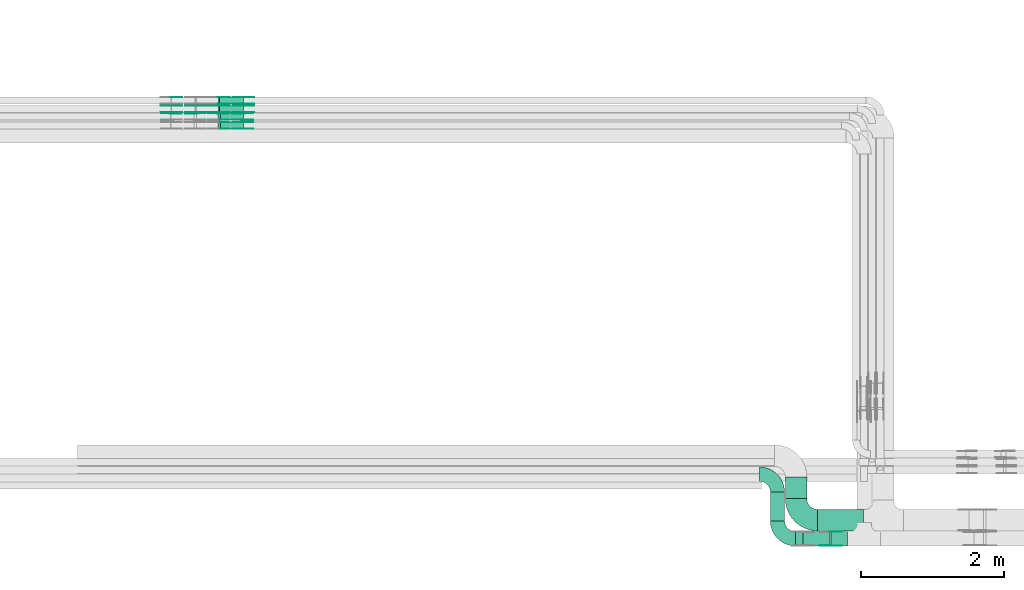
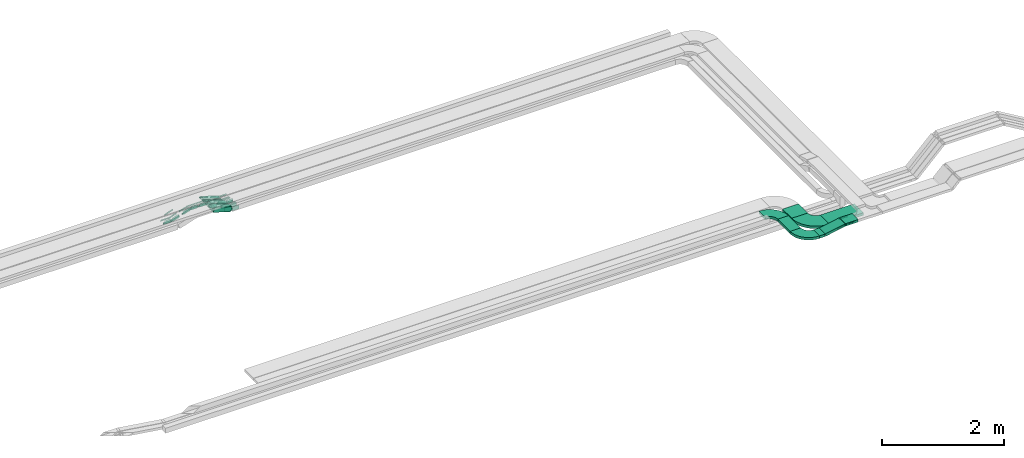
# One storey, part 13 of 19: 46 flow fittings, 10 flow segments.
"""IFC2X3 building model written with IfcOpenShell, lengths in millimetres."""

from ifc_helpers import new_model, entity, si_unit, converted_unit, derived_unit, direction, frame, frame_2d, origin, origin_2d_with_axis, place, context, subcontext, project, spatial, polyline, circle_curve, parameter, trimmed, segment, composite_curve, rectangle, outline, extrude, source, transform, mapped, material, type_object, type_shapes, element, save


model = new_model("IFC2X3")

# Units and contexts
model_context = context("Model", 3, precision=0.01, world=origin(), true_north=direction((6.12303176911189e-17, 1.0)))
body_context = subcontext(model_context, "Body", "Model", "MODEL_VIEW")
ifc_project = project(units=[si_unit("LENGTHUNIT", "METRE", prefix="MILLI"), si_unit("AREAUNIT", "SQUARE_METRE"), si_unit("VOLUMEUNIT", "CUBIC_METRE"), converted_unit("PLANEANGLEUNIT", "DEGREE", entity("IfcRatioMeasure", 0.0174532925199433), si_unit("PLANEANGLEUNIT", "RADIAN"), dimensions=[0, 0, 0, 0, 0, 0, 0]), si_unit("MASSUNIT", "GRAM", prefix="KILO"), derived_unit("MASSDENSITYUNIT", [(si_unit("MASSUNIT", "GRAM", prefix="KILO"), 1), (si_unit("LENGTHUNIT", "METRE"), -3)]), derived_unit("MOMENTOFINERTIAUNIT", [(si_unit("LENGTHUNIT", "METRE"), 4)]), si_unit("TIMEUNIT", "SECOND"), si_unit("FREQUENCYUNIT", "HERTZ"), si_unit("THERMODYNAMICTEMPERATUREUNIT", "DEGREE_CELSIUS"), derived_unit("THERMALTRANSMITTANCEUNIT", [(si_unit("MASSUNIT", "GRAM", prefix="KILO"), 1), (si_unit("THERMODYNAMICTEMPERATUREUNIT", "KELVIN"), -1), (si_unit("TIMEUNIT", "SECOND"), -3)]), derived_unit("VOLUMETRICFLOWRATEUNIT", [(si_unit("LENGTHUNIT", "METRE"), 3), (si_unit("TIMEUNIT", "SECOND"), -1)]), derived_unit("MASSFLOWRATEUNIT", [(si_unit("MASSUNIT", "GRAM", prefix="KILO"), 1), (si_unit("TIMEUNIT", "SECOND"), -1)]), derived_unit("ROTATIONALFREQUENCYUNIT", [(si_unit("TIMEUNIT", "SECOND"), -1)]), si_unit("ELECTRICCURRENTUNIT", "AMPERE"), si_unit("ELECTRICVOLTAGEUNIT", "VOLT"), si_unit("POWERUNIT", "WATT"), si_unit("FORCEUNIT", "NEWTON", prefix="KILO"), si_unit("ILLUMINANCEUNIT", "LUX"), si_unit("LUMINOUSFLUXUNIT", "LUMEN"), si_unit("LUMINOUSINTENSITYUNIT", "CANDELA"), derived_unit("USERDEFINED", [(si_unit("MASSUNIT", "GRAM", prefix="KILO"), -1), (si_unit("LENGTHUNIT", "METRE"), -2), (si_unit("TIMEUNIT", "SECOND"), 3), (si_unit("LUMINOUSFLUXUNIT", "LUMEN"), 1)]), derived_unit("LINEARVELOCITYUNIT", [(si_unit("LENGTHUNIT", "METRE"), 1), (si_unit("TIMEUNIT", "SECOND"), -1)]), si_unit("PRESSUREUNIT", "PASCAL"), derived_unit("USERDEFINED", [(si_unit("LENGTHUNIT", "METRE"), -2), (si_unit("MASSUNIT", "GRAM", prefix="KILO"), 1), (si_unit("TIMEUNIT", "SECOND"), -2)]), derived_unit("LINEARFORCEUNIT", [(si_unit("MASSUNIT", "GRAM", prefix="KILO"), 1), (si_unit("LENGTHUNIT", "METRE"), 1), (si_unit("TIMEUNIT", "SECOND"), -2), (si_unit("LENGTHUNIT", "METRE"), -1)]), derived_unit("PLANARFORCEUNIT", [(si_unit("MASSUNIT", "GRAM", prefix="KILO"), 1), (si_unit("LENGTHUNIT", "METRE"), 1), (si_unit("TIMEUNIT", "SECOND"), -2), (si_unit("LENGTHUNIT", "METRE"), -2)])], contexts=[model_context])

# Site, building, storey
site_placement = place(None, origin())
site = spatial("IfcSite", under=ifc_project, at=site_placement, CompositionType="ELEMENT")
building_placement = place(site_placement, origin())
building = spatial("IfcBuilding", under=site, at=building_placement, CompositionType="ELEMENT")
storey_placement = place(building_placement, frame((0.0, 0.0, 12000.0)))
storey = spatial("IfcBuildingStorey", under=building, at=storey_placement, CompositionType="ELEMENT", Elevation=12000.0)

# Flow segments
cable_carrier_segment_type = type_object("IfcCableCarrierSegmentType", PredefinedType="CABLETRAYSEGMENT")
flow_segment_1_placement = place(storey_placement, frame((51166.35, 14792.5, 2502.95)))
element("IfcFlowSegment", 1, at=flow_segment_1_placement, inside=storey, type_object=cable_carrier_segment_type, context=body_context, shape_type="SweptSolid", body=[
    extrude(rectangle(XDim=50.0000000000005, YDim=99.9999999999989, at=origin_2d_with_axis()), frame((7.73, 50.0, 131.57), z_axis=(0.951056516295132, 0.0, -0.309016994375015), x_axis=(0.309016994375015, 0.0, 0.951056516295132)), (0.0, 0.0, 1.0), 348.813702461219),
])
flow_segment_2_placement = place(storey_placement, frame((51166.35, 14673.63, 2502.95)))
element("IfcFlowSegment", 2, at=flow_segment_2_placement, inside=storey, type_object=cable_carrier_segment_type, context=body_context, shape_type="SweptSolid", body=[
    extrude(rectangle(XDim=50.0000000000005, YDim=99.9999999999989, at=origin_2d_with_axis()), frame((7.73, 50.0, 131.57), z_axis=(0.951056516295132, 0.0, -0.309016994375015), x_axis=(0.309016994375015, 0.0, 0.951056516295132)), (0.0, 0.0, 1.0), 348.813702461386),
])
flow_segment_3_placement = place(storey_placement, frame((51159.12, 14442.5, 2505.4)))
element("IfcFlowSegment", 3, at=flow_segment_3_placement, inside=storey, type_object=cable_carrier_segment_type, context=body_context, shape_type="SweptSolid", body=[
    extrude(rectangle(XDim=100.000000000001, YDim=99.9999999999989, at=origin_2d_with_axis()), frame((15.45, 50.0, 152.9), z_axis=(0.951056516295132, 0.0, -0.309016994375015), x_axis=(0.309016994375015, 0.0, 0.951056516295132)), (0.0, 0.0, 1.0), 340.89448044528),
])
flow_segment_4_placement = place(storey_placement, frame((59726.19, 8613.82, 2870.0)))
element("IfcFlowSegment", 4, at=flow_segment_4_placement, inside=storey, type_object=cable_carrier_segment_type, context=body_context, shape_type="SweptSolid", body=[
    extrude(rectangle(XDim=236.362563853772, YDim=200.0, at=origin_2d_with_axis()), frame((118.18, 100.0, 0.0)), (0.0, 0.0, 1.0), 49.9999999999995),
])
flow_segment_5_placement = place(storey_placement, frame((51159.12, 14566.24, 2505.4)))
element("IfcFlowSegment", 5, at=flow_segment_5_placement, inside=storey, type_object=cable_carrier_segment_type, context=body_context, shape_type="SweptSolid", body=[
    extrude(rectangle(XDim=100.000000000001, YDim=99.9999999999989, at=origin_2d_with_axis()), frame((15.45, 50.0, 152.9), z_axis=(0.951056516295132, 0.0, -0.309016994375015), x_axis=(0.309016994375015, 0.0, 0.951056516295132)), (0.0, 0.0, 1.0), 340.894480445334),
])
flow_segment_6_placement = place(storey_placement, frame((59339.96, 8613.82, 2801.07)))
element("IfcFlowSegment", 6, at=flow_segment_6_placement, inside=storey, type_object=cable_carrier_segment_type, context=body_context, shape_type="SweptSolid", body=[
    extrude(rectangle(XDim=50.0000000000028, YDim=200.0, at=frame_2d((0.0, 0.0), x_axis=(0.0, 1.0))), frame((4.51, 100.0, 24.59), z_axis=(0.98359332593574, 0.0, 0.180400025428684), x_axis=(0.0, 1.0, 0.0)), (0.0, 0.0, 1.0), 380.751680548762),
])
flow_segment_7_placement = place(storey_placement, frame((59231.89, 8613.82, 2800.0)))
element("IfcFlowSegment", 7, at=flow_segment_7_placement, inside=storey, type_object=cable_carrier_segment_type, context=body_context, shape_type="SweptSolid", body=[
    extrude(rectangle(XDim=105.36256385375, YDim=200.0, at=origin_2d_with_axis()), frame((52.68, 100.0, 0.0), z_axis=(0.0, 0.0, 1.0), x_axis=(-1.0, 0.0, 0.0)), (0.0, 0.0, 1.0), 50.0000000000016),
])
flow_segment_8_placement = place(storey_placement, frame((58880.89, 8964.82, 2800.0)))
element("IfcFlowSegment", 8, at=flow_segment_8_placement, inside=storey, type_object=cable_carrier_segment_type, context=body_context, shape_type="SweptSolid", body=[
    extrude(rectangle(XDim=401.312790454062, YDim=200.000000000007, at=origin_2d_with_axis()), frame((100.0, 200.66, 0.0), z_axis=(0.0, 0.0, 1.0), x_axis=(0.0, 1.0, 0.0)), (0.0, 0.0, 1.0), 50.0000000000016),
])
flow_segment_9_placement = place(storey_placement, frame((59541.89, 8824.99, 2800.0)))
element("IfcFlowSegment", 9, at=flow_segment_9_placement, inside=storey, type_object=cable_carrier_segment_type, context=body_context, shape_type="SweptSolid", body=[
    extrude(rectangle(XDim=640.660327660523, YDim=299.999999999999, at=origin_2d_with_axis()), frame((320.33, 150.0, 0.0), z_axis=(0.0, 0.0, 1.0), x_axis=(-1.0, 0.0, 0.0)), (0.0, 0.0, 1.0), 50.0000000000016),
])
flow_segment_10_placement = place(storey_placement, frame((59090.89, 9275.99, 2800.0)))
element("IfcFlowSegment", 10, at=flow_segment_10_placement, inside=storey, type_object=cable_carrier_segment_type, context=body_context, shape_type="SweptSolid", body=[
    extrude(rectangle(XDim=300.142155039271, YDim=300.000000000001, at=origin_2d_with_axis()), frame((150.0, 150.07, 0.0), z_axis=(0.0, 0.0, 1.0), x_axis=(0.0, 1.0, 0.0)), (0.0, 0.0, 1.0), 50.0000000000016),
])

# Flow fittings
ifc_material_1 = material()
cable_carrier_fitting_type_1 = type_object("IfcCableCarrierFittingType", Name="470_DKC_S5_Variable Angle Elbow 0-45:-", PredefinedType="NOTDEFINED", material=ifc_material_1)
shared_shape_1 = source(origin(), body_context, "Body", "SweptSolid", [
    extrude(outline(composite_curve([segment(polyline([(-150.75, -300.25), (-149.75, -300.25)]), True, "CONTINUOUS"), segment(trimmed(circle_curve(frame_2d((-149.75, 149.75), x_axis=(0.0, -1.0)), 450.0), [parameter(0.0)], [parameter(90.0000000000001)], True, "PARAMETER"), True, "CONTINUOUS"), segment(polyline([(300.25, 149.75), (300.25, 150.75)]), True, "CONTINUOUS"), segment(polyline([(300.25, 150.75), (0.25, 150.75)]), True, "CONTINUOUS"), segment(polyline([(0.25, 150.75), (0.25, 149.75)]), True, "CONTINUOUS"), segment(trimmed(circle_curve(frame_2d((-149.75, 149.75), x_axis=(0.0, -1.0)), 150.0), [parameter(0.0)], [parameter(90.0000000000001)], True, "PARAMETER"), False, "CONTINUOUS"), segment(polyline([(-149.75, -0.25), (-150.75, -0.25)]), True, "CONTINUOUS"), segment(polyline([(-150.75, -0.25), (-150.75, -300.25)]), True, "CONTINUOUS")], self_intersect=False)), frame((-150.25, 150.25, -25.0)), (0.0, 0.0, 1.0), 49.9999999999974),
])
type_shapes(cable_carrier_fitting_type_1, [shared_shape_1])
flow_fitting_1_placement = place(storey_placement, frame((59240.89, 8974.99, 2825.0), z_axis=(0.0, 0.0, 1.0), x_axis=(0.0, -1.0, 0.0)))
element("IfcFlowFitting", 11, at=flow_fitting_1_placement, inside=storey, type_object=cable_carrier_fitting_type_1, material=ifc_material_1, Name="470_DKC_S5_Variable Angle Elbow 0-45:-", ObjectType="470_DKC_S5_Variable Angle Elbow 0-45:-", context=body_context, shape_type="MappedRepresentation", body=[
    mapped(shared_shape_1, transform((0.0, 0.0, 0.0), scale=1.0)),
])
ifc_material_2 = material(Name="G")
cable_carrier_fitting_type_2 = type_object("IfcCableCarrierFittingType", PredefinedType="NOTDEFINED", material=ifc_material_2)
shared_shape_2 = source(origin(), body_context, "Body", "SweptSolid", [
    extrude(outline(composite_curve([segment(trimmed(circle_curve(frame_2d((-44.59, 0.0), x_axis=(1.0, 0.0)), 12.5), [parameter(90.0000000000007)], [parameter(270.0)], True, "PARAMETER"), True, "CONTINUOUS"), segment(polyline([(-44.59, -12.5), (-33.09, -12.5)]), True, "CONTINUOUS"), segment(polyline([(-33.09, -12.5), (-31.23, -14.5)]), True, "CONTINUOUS"), segment(polyline([(-31.23, -14.5), (108.91, -14.5)]), True, "CONTINUOUS"), segment(polyline([(108.91, -14.5), (108.91, 14.5)]), True, "CONTINUOUS"), segment(polyline([(108.91, 14.5), (-31.23, 14.5)]), True, "CONTINUOUS"), segment(polyline([(-31.23, 14.5), (-33.09, 12.5)]), True, "CONTINUOUS"), segment(polyline([(-33.09, 12.5), (-44.59, 12.5)]), True, "CONTINUOUS")], self_intersect=False)), frame((44.59, 0.0, 0.0), z_axis=(0.0, 0.0, -1.0), x_axis=(1.0, 0.0, 0.0)), (0.0, 0.0, -1.0), 2.0),
])
type_shapes(cable_carrier_fitting_type_2, [shared_shape_2])
flow_fitting_2_placement = place(storey_placement, frame((51511.13, 14887.96, 2525.0), z_axis=(0.0, 1.0, 0.0), x_axis=(-0.951056516295154, 0.0, 0.309016994374945)))
element("IfcFlowFitting", 12, at=flow_fitting_2_placement, inside=storey, type_object=cable_carrier_fitting_type_2, material=ifc_material_2, context=body_context, shape_type="MappedRepresentation", body=[
    mapped(shared_shape_2, transform((0.0, 0.0, 0.0), scale=1.0)),
])
cable_carrier_fitting_type_3 = type_object("IfcCableCarrierFittingType", PredefinedType="NOTDEFINED", material=ifc_material_2)
type_shapes(cable_carrier_fitting_type_3, [shared_shape_2])
for number, where, z_axis, x_axis in (
    (13, (51511.13, 14799.04, 2525.0), (0.0, -1.0, 0.0), (1.0, 0.0, 0.0)),
    (14, (51168.75, 14885.96, 2636.25), (0.0, 1.0, 0.0), (0.951056516295156, 0.0, -0.309016994374939)),
):
    element("IfcFlowFitting", number, at=place(storey_placement, frame(where, z_axis=z_axis, x_axis=x_axis)), inside=storey, type_object=cable_carrier_fitting_type_3, material=ifc_material_2, context=body_context, shape_type="MappedRepresentation", body=[
        mapped(shared_shape_2, transform((0.0, 0.0, 0.0), scale=1.0)),
    ])
flow_fitting_3_placement = place(storey_placement, frame((51168.75, 14678.17, 2636.25), z_axis=(0.0, -1.0, 0.0), x_axis=(-1.0, 0.0, 0.0)))
element("IfcFlowFitting", 15, at=flow_fitting_3_placement, inside=storey, type_object=cable_carrier_fitting_type_2, material=ifc_material_2, context=body_context, shape_type="MappedRepresentation", body=[
    mapped(shared_shape_2, transform((0.0, 0.0, 0.0), scale=1.0)),
])
flow_fitting_4_placement = place(storey_placement, frame((51168.75, 14767.09, 2636.25), z_axis=(0.0, 1.0, 0.0), x_axis=(0.951056516295156, 0.0, -0.309016994374939)))
element("IfcFlowFitting", 16, at=flow_fitting_4_placement, inside=storey, type_object=cable_carrier_fitting_type_3, material=ifc_material_2, context=body_context, shape_type="MappedRepresentation", body=[
    mapped(shared_shape_2, transform((0.0, 0.0, 0.0), scale=1.0)),
])
flow_fitting_5_placement = place(storey_placement, frame((50850.8, 14769.09, 2636.25), z_axis=(0.0, 1.0, 0.0), x_axis=(1.0, 0.0, 0.0)))
element("IfcFlowFitting", 17, at=flow_fitting_5_placement, inside=storey, type_object=cable_carrier_fitting_type_2, material=ifc_material_2, context=body_context, shape_type="MappedRepresentation", body=[
    mapped(shared_shape_2, transform((0.0, 0.0, 0.0), scale=1.0)),
])
flow_fitting_6_placement = place(storey_placement, frame((50850.8, 14680.17, 2636.25), z_axis=(0.0, -1.0, 0.0), x_axis=(-0.951056516295156, 0.0, -0.309016994374939)))
element("IfcFlowFitting", 18, at=flow_fitting_6_placement, inside=storey, type_object=cable_carrier_fitting_type_3, material=ifc_material_2, context=body_context, shape_type="MappedRepresentation", body=[
    mapped(shared_shape_2, transform((0.0, 0.0, 0.0), scale=1.0)),
])
flow_fitting_7_placement = place(storey_placement, frame((51511.13, 14678.17, 2525.0), z_axis=(0.0, -1.0, 0.0), x_axis=(1.0, 0.0, 0.0)))
element("IfcFlowFitting", 19, at=flow_fitting_7_placement, inside=storey, type_object=cable_carrier_fitting_type_2, material=ifc_material_2, context=body_context, shape_type="MappedRepresentation", body=[
    mapped(shared_shape_2, transform((0.0, 0.0, 0.0), scale=1.0)),
])
flow_fitting_8_placement = place(storey_placement, frame((51511.13, 14767.09, 2525.0), z_axis=(0.0, 1.0, 0.0), x_axis=(-0.951056516295154, 0.0, 0.309016994374945)))
element("IfcFlowFitting", 20, at=flow_fitting_8_placement, inside=storey, type_object=cable_carrier_fitting_type_3, material=ifc_material_2, context=body_context, shape_type="MappedRepresentation", body=[
    mapped(shared_shape_2, transform((0.0, 0.0, 0.0), scale=1.0)),
])
flow_fitting_9_placement = place(storey_placement, frame((50508.42, 14769.09, 2525.0), z_axis=(0.0, 1.0, 0.0), x_axis=(-1.0, 0.0, 0.0)))
element("IfcFlowFitting", 21, at=flow_fitting_9_placement, inside=storey, type_object=cable_carrier_fitting_type_2, material=ifc_material_2, context=body_context, shape_type="MappedRepresentation", body=[
    mapped(shared_shape_2, transform((0.0, 0.0, 0.0), scale=1.0)),
])
flow_fitting_10_placement = place(storey_placement, frame((50508.42, 14680.17, 2525.0), z_axis=(0.0, -1.0, 0.0), x_axis=(0.951056516295156, 0.0, 0.30901699437494)))
element("IfcFlowFitting", 22, at=flow_fitting_10_placement, inside=storey, type_object=cable_carrier_fitting_type_3, material=ifc_material_2, context=body_context, shape_type="MappedRepresentation", body=[
    mapped(shared_shape_2, transform((0.0, 0.0, 0.0), scale=1.0)),
])
flow_fitting_11_placement = place(storey_placement, frame((59722.55, 8809.28, 2895.0), z_axis=(0.0, 1.0, 0.0), x_axis=(1.0, 0.0, 0.0)))
element("IfcFlowFitting", 23, at=flow_fitting_11_placement, inside=storey, type_object=cable_carrier_fitting_type_2, material=ifc_material_2, context=body_context, shape_type="MappedRepresentation", body=[
    mapped(shared_shape_2, transform((0.0, 0.0, 0.0), scale=1.0)),
])
flow_fitting_12_placement = place(storey_placement, frame((59722.55, 8620.36, 2895.0), z_axis=(0.0, -1.0, 0.0), x_axis=(-0.983593325935759, 0.0, -0.180400025428576)))
element("IfcFlowFitting", 24, at=flow_fitting_12_placement, inside=storey, type_object=cable_carrier_fitting_type_3, material=ifc_material_2, context=body_context, shape_type="MappedRepresentation", body=[
    mapped(shared_shape_2, transform((0.0, 0.0, 0.0), scale=1.0)),
])
cable_carrier_fitting_type_4 = type_object("IfcCableCarrierFittingType", PredefinedType="NOTDEFINED", material=ifc_material_2)
shared_shape_3 = source(origin(), body_context, "Body", "SweptSolid", [
    extrude(outline(composite_curve([segment(trimmed(circle_curve(frame_2d((-44.59, 0.0), x_axis=(1.0, 0.0)), 12.5), [parameter(90.0000000000007)], [parameter(270.0)], True, "PARAMETER"), True, "CONTINUOUS"), segment(polyline([(-44.59, -12.5), (-33.09, -12.5)]), True, "CONTINUOUS"), segment(polyline([(-33.09, -12.5), (-31.23, -14.5)]), True, "CONTINUOUS"), segment(polyline([(-31.23, -14.5), (108.91, -14.5)]), True, "CONTINUOUS"), segment(polyline([(108.91, -14.5), (108.91, 14.5)]), True, "CONTINUOUS"), segment(polyline([(108.91, 14.5), (-31.23, 14.5)]), True, "CONTINUOUS"), segment(polyline([(-31.23, 14.5), (-33.09, 12.5)]), True, "CONTINUOUS"), segment(polyline([(-33.09, 12.5), (-44.59, 12.5)]), True, "CONTINUOUS")], self_intersect=False)), frame((44.59, 0.0, 0.0)), (0.0, 0.0, 1.0), 2.0),
])
type_shapes(cable_carrier_fitting_type_4, [shared_shape_3])
flow_fitting_13_placement = place(storey_placement, frame((51511.13, 14797.04, 2525.0), z_axis=(0.0, -1.0, 0.0), x_axis=(-0.951056516295154, 0.0, 0.309016994374945)))
element("IfcFlowFitting", 25, at=flow_fitting_13_placement, inside=storey, type_object=cable_carrier_fitting_type_4, material=ifc_material_2, context=body_context, shape_type="MappedRepresentation", body=[
    mapped(shared_shape_3, transform((0.0, 0.0, 0.0), scale=1.0)),
])
cable_carrier_fitting_type_5 = type_object("IfcCableCarrierFittingType", PredefinedType="NOTDEFINED", material=ifc_material_2)
type_shapes(cable_carrier_fitting_type_5, [shared_shape_3])
for number, where, z_axis, x_axis in (
    (26, (51511.13, 14885.96, 2525.0), (0.0, 1.0, 0.0), (1.0, 0.0, 0.0)),
    (27, (51168.75, 14799.04, 2636.25), (0.0, -1.0, 0.0), (0.951056516295156, 0.0, -0.309016994374939)),
    (28, (50508.42, 14885.96, 2525.0), (0.0, 1.0, 0.0), (0.951056516295156, 0.0, 0.309016994374939)),
):
    element("IfcFlowFitting", number, at=place(storey_placement, frame(where, z_axis=z_axis, x_axis=x_axis)), inside=storey, type_object=cable_carrier_fitting_type_5, material=ifc_material_2, context=body_context, shape_type="MappedRepresentation", body=[
        mapped(shared_shape_3, transform((0.0, 0.0, 0.0), scale=1.0)),
    ])
flow_fitting_14_placement = place(storey_placement, frame((51168.75, 14769.09, 2636.25), z_axis=(0.0, 1.0, 0.0), x_axis=(-1.0, 0.0, 0.0)))
element("IfcFlowFitting", 29, at=flow_fitting_14_placement, inside=storey, type_object=cable_carrier_fitting_type_4, material=ifc_material_2, context=body_context, shape_type="MappedRepresentation", body=[
    mapped(shared_shape_3, transform((0.0, 0.0, 0.0), scale=1.0)),
])
flow_fitting_15_placement = place(storey_placement, frame((51168.75, 14680.17, 2636.25), z_axis=(0.0, -1.0, 0.0), x_axis=(0.951056516295156, 0.0, -0.309016994374939)))
element("IfcFlowFitting", 30, at=flow_fitting_15_placement, inside=storey, type_object=cable_carrier_fitting_type_5, material=ifc_material_2, context=body_context, shape_type="MappedRepresentation", body=[
    mapped(shared_shape_3, transform((0.0, 0.0, 0.0), scale=1.0)),
])
flow_fitting_16_placement = place(storey_placement, frame((50850.8, 14678.17, 2636.25), z_axis=(0.0, -1.0, 0.0), x_axis=(1.0, 0.0, 0.0)))
element("IfcFlowFitting", 31, at=flow_fitting_16_placement, inside=storey, type_object=cable_carrier_fitting_type_4, material=ifc_material_2, context=body_context, shape_type="MappedRepresentation", body=[
    mapped(shared_shape_3, transform((0.0, 0.0, 0.0), scale=1.0)),
])
flow_fitting_17_placement = place(storey_placement, frame((50850.8, 14767.09, 2636.25), z_axis=(0.0, 1.0, 0.0), x_axis=(-0.951056516295156, 0.0, -0.309016994374939)))
element("IfcFlowFitting", 32, at=flow_fitting_17_placement, inside=storey, type_object=cable_carrier_fitting_type_5, material=ifc_material_2, context=body_context, shape_type="MappedRepresentation", body=[
    mapped(shared_shape_3, transform((0.0, 0.0, 0.0), scale=1.0)),
])
flow_fitting_18_placement = place(storey_placement, frame((51511.13, 14769.09, 2525.0), z_axis=(0.0, 1.0, 0.0), x_axis=(1.0, 0.0, 0.0)))
element("IfcFlowFitting", 33, at=flow_fitting_18_placement, inside=storey, type_object=cable_carrier_fitting_type_4, material=ifc_material_2, context=body_context, shape_type="MappedRepresentation", body=[
    mapped(shared_shape_3, transform((0.0, 0.0, 0.0), scale=1.0)),
])
flow_fitting_19_placement = place(storey_placement, frame((51511.13, 14680.17, 2525.0), z_axis=(0.0, -1.0, 0.0), x_axis=(-0.951056516295154, 0.0, 0.309016994374945)))
element("IfcFlowFitting", 34, at=flow_fitting_19_placement, inside=storey, type_object=cable_carrier_fitting_type_5, material=ifc_material_2, context=body_context, shape_type="MappedRepresentation", body=[
    mapped(shared_shape_3, transform((0.0, 0.0, 0.0), scale=1.0)),
])
flow_fitting_20_placement = place(storey_placement, frame((50508.42, 14678.17, 2525.0), z_axis=(0.0, -1.0, 0.0), x_axis=(-1.0, 0.0, 0.0)))
element("IfcFlowFitting", 35, at=flow_fitting_20_placement, inside=storey, type_object=cable_carrier_fitting_type_4, material=ifc_material_2, context=body_context, shape_type="MappedRepresentation", body=[
    mapped(shared_shape_3, transform((0.0, 0.0, 0.0), scale=1.0)),
])
flow_fitting_21_placement = place(storey_placement, frame((50508.42, 14767.09, 2525.0), z_axis=(0.0, 1.0, 0.0), x_axis=(0.951056516295156, 0.0, 0.30901699437494)))
element("IfcFlowFitting", 36, at=flow_fitting_21_placement, inside=storey, type_object=cable_carrier_fitting_type_5, material=ifc_material_2, context=body_context, shape_type="MappedRepresentation", body=[
    mapped(shared_shape_3, transform((0.0, 0.0, 0.0), scale=1.0)),
])
flow_fitting_22_placement = place(storey_placement, frame((59722.55, 8618.36, 2895.0), z_axis=(0.0, -1.0, 0.0), x_axis=(1.0, 0.0, 0.0)))
element("IfcFlowFitting", 37, at=flow_fitting_22_placement, inside=storey, type_object=cable_carrier_fitting_type_4, material=ifc_material_2, context=body_context, shape_type="MappedRepresentation", body=[
    mapped(shared_shape_3, transform((0.0, 0.0, 0.0), scale=1.0)),
])
cable_carrier_fitting_type_6 = type_object("IfcCableCarrierFittingType", Name="470_DKC_S5_Variable Angle Elbow 0-45:-", PredefinedType="NOTDEFINED", material=ifc_material_1)
shared_shape_4 = source(origin(), body_context, "Body", "SweptSolid", [
    extrude(outline(composite_curve([segment(polyline([(-125.75, -225.25), (-124.75, -225.25)]), True, "CONTINUOUS"), segment(trimmed(circle_curve(frame_2d((-124.75, 124.75), x_axis=(0.0, -1.0)), 350.0), [parameter(0.0)], [parameter(90.0000000000001)], True, "PARAMETER"), True, "CONTINUOUS"), segment(polyline([(225.25, 124.75), (225.25, 125.75)]), True, "CONTINUOUS"), segment(polyline([(225.25, 125.75), (25.25, 125.75)]), True, "CONTINUOUS"), segment(polyline([(25.25, 125.75), (25.25, 124.75)]), True, "CONTINUOUS"), segment(trimmed(circle_curve(frame_2d((-124.75, 124.75), x_axis=(0.0, -1.0)), 150.0), [parameter(0.0)], [parameter(90.0000000000001)], True, "PARAMETER"), False, "CONTINUOUS"), segment(polyline([(-124.75, -25.25), (-125.75, -25.25)]), True, "CONTINUOUS"), segment(polyline([(-125.75, -25.25), (-125.75, -225.25)]), True, "CONTINUOUS")], self_intersect=False)), frame((-125.25, 125.25, -25.0)), (0.0, 0.0, 1.0), 50.000000000001),
])
type_shapes(cable_carrier_fitting_type_6, [shared_shape_4])
for number, where, z_axis, x_axis, name in (
    (38, (58980.89, 8713.82, 2825.0), (0.0, 0.0, 1.0), (0.0, -1.0, 0.0), "470_DKC_S5_Variable Angle Elbow 0-45:-"),
    (39, (58980.89, 9617.13, 2825.0), (0.0, 0.0, 1.0), (0.0, 1.0, 0.0), "470_DKC_S5_Variable Angle Elbow 0-45:-"),
):
    element("IfcFlowFitting", number, at=place(storey_placement, frame(where, z_axis=z_axis, x_axis=x_axis)), inside=storey, type_object=cable_carrier_fitting_type_6, material=ifc_material_1, Name=name, ObjectType="470_DKC_S5_Variable Angle Elbow 0-45:-", context=body_context, shape_type="MappedRepresentation", body=[
        mapped(shared_shape_4, transform((0.0, 0.0, 0.0), scale=1.0)),
    ])
cable_carrier_fitting_type_7 = type_object("IfcCableCarrierFittingType", PredefinedType="NOTDEFINED", material=ifc_material_2)
shared_shape_5 = source(origin(), body_context, "Body", "SweptSolid", [
    extrude(outline(composite_curve([segment(trimmed(circle_curve(frame_2d((-41.47, 0.0), x_axis=(1.0, 0.0)), 25.0), [parameter(90.0000000000007)], [parameter(270.0)], True, "PARAMETER"), True, "CONTINUOUS"), segment(polyline([(-41.47, -25.0), (-29.97, -25.0)]), True, "CONTINUOUS"), segment(polyline([(-29.97, -25.0), (-28.1, -38.5)]), True, "CONTINUOUS"), segment(polyline([(-28.1, -38.5), (99.53, -38.5)]), True, "CONTINUOUS"), segment(polyline([(99.53, -38.5), (99.53, 38.5)]), True, "CONTINUOUS"), segment(polyline([(99.53, 38.5), (-28.1, 38.5)]), True, "CONTINUOUS"), segment(polyline([(-28.1, 38.5), (-29.97, 25.0)]), True, "CONTINUOUS"), segment(polyline([(-29.97, 25.0), (-41.47, 25.0)]), True, "CONTINUOUS")], self_intersect=False)), frame((41.47, 0.0, 0.0), z_axis=(0.0, 0.0, -1.0), x_axis=(1.0, 0.0, 0.0)), (0.0, 0.0, -1.0), 2.0),
])
type_shapes(cable_carrier_fitting_type_7, [shared_shape_5])
flow_fitting_23_placement = place(storey_placement, frame((51165.49, 14535.96, 2661.25), z_axis=(0.0, 1.0, 0.0), x_axis=(0.951056516295156, 0.0, -0.309016994374939)))
element("IfcFlowFitting", 40, at=flow_fitting_23_placement, inside=storey, type_object=cable_carrier_fitting_type_7, material=ifc_material_2, context=body_context, shape_type="MappedRepresentation", body=[
    mapped(shared_shape_5, transform((0.0, 0.0, 0.0), scale=1.0)),
])
cable_carrier_fitting_type_8 = type_object("IfcCableCarrierFittingType", PredefinedType="NOTDEFINED", material=ifc_material_2)
type_shapes(cable_carrier_fitting_type_8, [shared_shape_5])
flow_fitting_24_placement = place(storey_placement, frame((51507.87, 14447.04, 2550.0), z_axis=(0.0, -1.0, 0.0), x_axis=(1.0, 0.0, 0.0)))
element("IfcFlowFitting", 41, at=flow_fitting_24_placement, inside=storey, type_object=cable_carrier_fitting_type_8, material=ifc_material_2, context=body_context, shape_type="MappedRepresentation", body=[
    mapped(shared_shape_5, transform((0.0, 0.0, 0.0), scale=1.0)),
])
for number, where, z_axis, x_axis in (
    (42, (51507.87, 14535.96, 2550.0), (0.0, 1.0, 0.0), (-0.951056516295156, 0.0, 0.30901699437494)),
    (43, (51165.49, 14659.7, 2661.25), (0.0, 1.0, 0.0), (0.951056516295156, 0.0, -0.309016994374939)),
):
    element("IfcFlowFitting", number, at=place(storey_placement, frame(where, z_axis=z_axis, x_axis=x_axis)), inside=storey, type_object=cable_carrier_fitting_type_7, material=ifc_material_2, context=body_context, shape_type="MappedRepresentation", body=[
        mapped(shared_shape_5, transform((0.0, 0.0, 0.0), scale=1.0)),
    ])
for number, where, z_axis, x_axis in (
    (44, (50847.54, 14661.7, 2661.25), (0.0, 1.0, 0.0), (1.0, 0.0, 0.0)),
    (45, (51507.87, 14570.78, 2550.0), (0.0, -1.0, 0.0), (1.0, 0.0, 0.0)),
):
    element("IfcFlowFitting", number, at=place(storey_placement, frame(where, z_axis=z_axis, x_axis=x_axis)), inside=storey, type_object=cable_carrier_fitting_type_8, material=ifc_material_2, context=body_context, shape_type="MappedRepresentation", body=[
        mapped(shared_shape_5, transform((0.0, 0.0, 0.0), scale=1.0)),
    ])
flow_fitting_25_placement = place(storey_placement, frame((51507.87, 14659.7, 2550.0), z_axis=(0.0, 1.0, 0.0), x_axis=(-0.951056516295154, 0.0, 0.309016994374947)))
element("IfcFlowFitting", 46, at=flow_fitting_25_placement, inside=storey, type_object=cable_carrier_fitting_type_7, material=ifc_material_2, context=body_context, shape_type="MappedRepresentation", body=[
    mapped(shared_shape_5, transform((0.0, 0.0, 0.0), scale=1.0)),
])
flow_fitting_26_placement = place(storey_placement, frame((50505.16, 14661.7, 2550.0), z_axis=(0.0, 1.0, 0.0), x_axis=(-1.0, 0.0, 0.0)))
element("IfcFlowFitting", 47, at=flow_fitting_26_placement, inside=storey, type_object=cable_carrier_fitting_type_8, material=ifc_material_2, context=body_context, shape_type="MappedRepresentation", body=[
    mapped(shared_shape_5, transform((0.0, 0.0, 0.0), scale=1.0)),
])
cable_carrier_fitting_type_9 = type_object("IfcCableCarrierFittingType", PredefinedType="NOTDEFINED", material=ifc_material_2)
shared_shape_6 = source(origin(), body_context, "Body", "SweptSolid", [
    extrude(outline(composite_curve([segment(trimmed(circle_curve(frame_2d((-41.47, 0.0), x_axis=(1.0, 0.0)), 25.0), [parameter(90.0000000000007)], [parameter(270.0)], True, "PARAMETER"), True, "CONTINUOUS"), segment(polyline([(-41.47, -25.0), (-29.97, -25.0)]), True, "CONTINUOUS"), segment(polyline([(-29.97, -25.0), (-28.1, -38.5)]), True, "CONTINUOUS"), segment(polyline([(-28.1, -38.5), (99.53, -38.5)]), True, "CONTINUOUS"), segment(polyline([(99.53, -38.5), (99.53, 38.5)]), True, "CONTINUOUS"), segment(polyline([(99.53, 38.5), (-28.1, 38.5)]), True, "CONTINUOUS"), segment(polyline([(-28.1, 38.5), (-29.97, 25.0)]), True, "CONTINUOUS"), segment(polyline([(-29.97, 25.0), (-41.47, 25.0)]), True, "CONTINUOUS")], self_intersect=False)), frame((41.47, 0.0, 0.0)), (0.0, 0.0, 1.0), 2.0),
])
type_shapes(cable_carrier_fitting_type_9, [shared_shape_6])
flow_fitting_27_placement = place(storey_placement, frame((51165.49, 14449.04, 2661.25), z_axis=(0.0, -1.0, 0.0), x_axis=(0.951056516295156, 0.0, -0.309016994374939)))
element("IfcFlowFitting", 48, at=flow_fitting_27_placement, inside=storey, type_object=cable_carrier_fitting_type_9, material=ifc_material_2, context=body_context, shape_type="MappedRepresentation", body=[
    mapped(shared_shape_6, transform((0.0, 0.0, 0.0), scale=1.0)),
])
cable_carrier_fitting_type_10 = type_object("IfcCableCarrierFittingType", PredefinedType="NOTDEFINED", material=ifc_material_2)
type_shapes(cable_carrier_fitting_type_10, [shared_shape_6])
flow_fitting_28_placement = place(storey_placement, frame((51507.87, 14537.96, 2550.0), z_axis=(0.0, 1.0, 0.0), x_axis=(1.0, 0.0, 0.0)))
element("IfcFlowFitting", 49, at=flow_fitting_28_placement, inside=storey, type_object=cable_carrier_fitting_type_10, material=ifc_material_2, context=body_context, shape_type="MappedRepresentation", body=[
    mapped(shared_shape_6, transform((0.0, 0.0, 0.0), scale=1.0)),
])
flow_fitting_29_placement = place(storey_placement, frame((51507.87, 14449.04, 2550.0), z_axis=(0.0, -1.0, 0.0), x_axis=(-0.951056516295156, 0.0, 0.30901699437494)))
element("IfcFlowFitting", 50, at=flow_fitting_29_placement, inside=storey, type_object=cable_carrier_fitting_type_9, material=ifc_material_2, context=body_context, shape_type="MappedRepresentation", body=[
    mapped(shared_shape_6, transform((0.0, 0.0, 0.0), scale=1.0)),
])
flow_fitting_30_placement = place(storey_placement, frame((51165.49, 14661.7, 2661.25), z_axis=(0.0, 1.0, 0.0), x_axis=(-1.0, 0.0, 0.0)))
element("IfcFlowFitting", 51, at=flow_fitting_30_placement, inside=storey, type_object=cable_carrier_fitting_type_10, material=ifc_material_2, context=body_context, shape_type="MappedRepresentation", body=[
    mapped(shared_shape_6, transform((0.0, 0.0, 0.0), scale=1.0)),
])
for number, where, z_axis, x_axis in (
    (52, (51165.49, 14572.78, 2661.25), (0.0, -1.0, 0.0), (0.951056516295156, 0.0, -0.309016994374939)),
    (53, (50847.54, 14659.7, 2661.25), (0.0, 1.0, 0.0), (-0.951056516295156, 0.0, -0.309016994374939)),
):
    element("IfcFlowFitting", number, at=place(storey_placement, frame(where, z_axis=z_axis, x_axis=x_axis)), inside=storey, type_object=cable_carrier_fitting_type_9, material=ifc_material_2, context=body_context, shape_type="MappedRepresentation", body=[
        mapped(shared_shape_6, transform((0.0, 0.0, 0.0), scale=1.0)),
    ])
flow_fitting_31_placement = place(storey_placement, frame((51507.87, 14661.7, 2550.0), z_axis=(0.0, 1.0, 0.0), x_axis=(1.0, 0.0, 0.0)))
element("IfcFlowFitting", 54, at=flow_fitting_31_placement, inside=storey, type_object=cable_carrier_fitting_type_10, material=ifc_material_2, context=body_context, shape_type="MappedRepresentation", body=[
    mapped(shared_shape_6, transform((0.0, 0.0, 0.0), scale=1.0)),
])
for number, where, z_axis, x_axis in (
    (55, (51507.87, 14572.78, 2550.0), (0.0, -1.0, 0.0), (-0.951056516295154, 0.0, 0.309016994374947)),
    (56, (50505.16, 14659.7, 2550.0), (0.0, 1.0, 0.0), (0.951056516295155, 0.0, 0.309016994374944)),
):
    element("IfcFlowFitting", number, at=place(storey_placement, frame(where, z_axis=z_axis, x_axis=x_axis)), inside=storey, type_object=cable_carrier_fitting_type_9, material=ifc_material_2, context=body_context, shape_type="MappedRepresentation", body=[
        mapped(shared_shape_6, transform((0.0, 0.0, 0.0), scale=1.0)),
    ])

save(model, "model.ifc")
